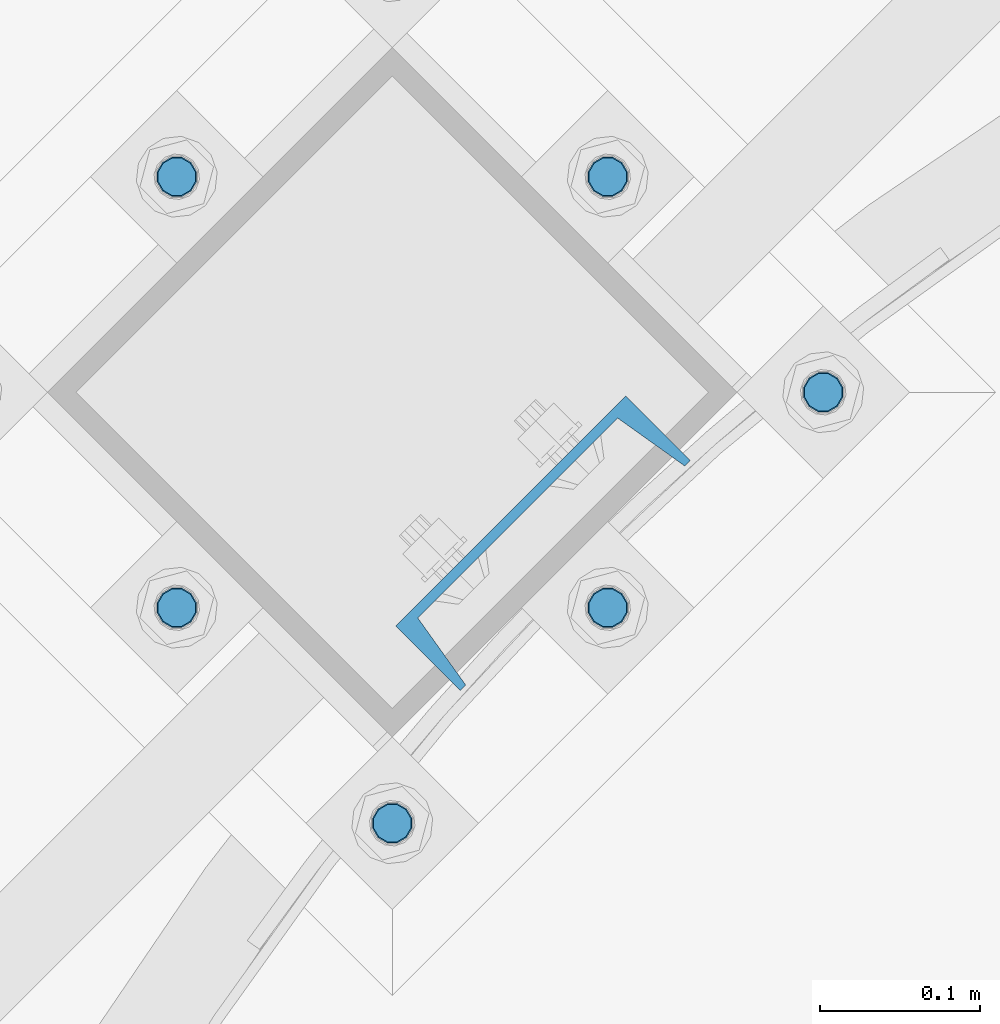
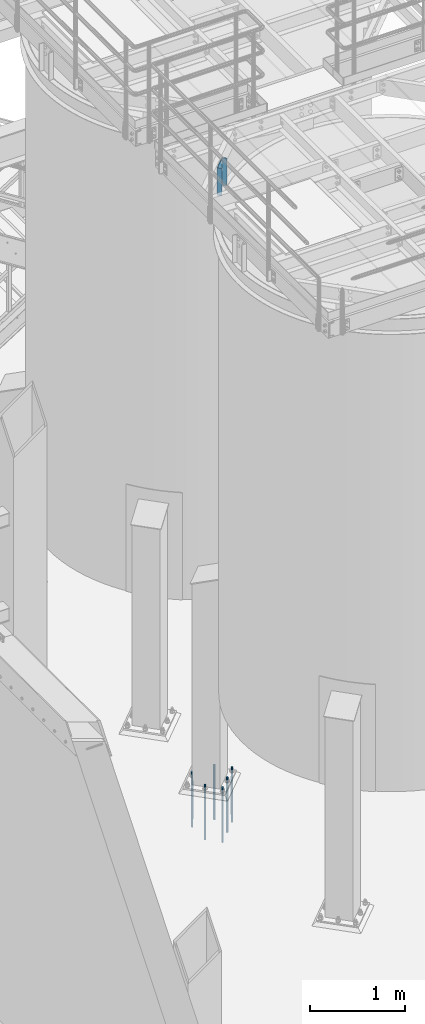
# One storey, part 787 of 1876: 7 columns, 2 elements without a shape of their own.
"""IFC2X3 building model written with IfcOpenShell, lengths in millimetres."""

from ifc_helpers import new_model, si_unit, frame, origin_with_axes, place, context, subcontext, project, spatial, faceted_brep, material, type_object, element, aggregate, save


model = new_model("IFC2X3")

# Units and contexts
model_context = context("Model", 3, precision=1e-05, world=origin_with_axes())
body_context = subcontext(model_context, "Body", "Model", "MODEL_VIEW")
ifc_project = project(units=[si_unit("LENGTHUNIT", "METRE", prefix="MILLI"), si_unit("AREAUNIT", "SQUARE_METRE"), si_unit("VOLUMEUNIT", "CUBIC_METRE"), si_unit("MASSUNIT", "GRAM", prefix="KILO"), si_unit("TIMEUNIT", "SECOND"), si_unit("PLANEANGLEUNIT", "RADIAN"), si_unit("SOLIDANGLEUNIT", "STERADIAN"), si_unit("THERMODYNAMICTEMPERATUREUNIT", "DEGREE_CELSIUS"), si_unit("LUMINOUSINTENSITYUNIT", "LUMEN")], contexts=[model_context])

# Site, building, storey
site_placement = place(None, origin_with_axes())
site = spatial("IfcSite", under=ifc_project, at=site_placement, CompositionType="ELEMENT")
building_placement = place(site_placement, origin_with_axes())
building = spatial("IfcBuilding", under=site, at=building_placement, Name="Undefined", CompositionType="ELEMENT")
storey_placement = place(building_placement, origin_with_axes())
storey = spatial("IfcBuildingStorey", under=building, at=storey_placement, Name="Undefined", CompositionType="ELEMENT", Elevation=0.0)

# Assembly, column
assembly_1_placement = place(storey_placement, origin_with_axes())
assembly_1 = element("IfcElementAssembly", 1, at=assembly_1_placement, inside=storey, Name="BEAM", AssemblyPlace="NOTDEFINED", PredefinedType="RIGID_FRAME")
ifc_material_1 = material(Name="STEEL/A36")
column_type_1 = type_object("IfcColumnType", Name="C8X11.5", PredefinedType="NOTDEFINED")
column_1_placement = place(assembly_1_placement, frame((3877.23669477331, -12284.6708589759, 7620.0), z_axis=(-0.707106781186547, -0.707106781186548, 0.0), x_axis=(0.0, 0.0, 1.0)))
column_1 = element("IfcColumn", 2, at=column_1_placement, type_object=column_type_1, material=ifc_material_1, Name="BEAM", ObjectType="C8X11.5", context=body_context, shape_type="Brep", body=[
    faceted_brep([(0.0, 28.5749999999998, -101.6), (0.0, 28.5749999999998, 101.6), (352.425, 28.5749999999998, 101.6), (352.425, 28.5749999999998, -101.6), (0.0, -28.5749999999998, 101.6), (352.425, -28.5749999999998, 101.6), (0.0, -28.5749999999998, 96.8355950000005), (352.425, -28.5749999999998, 96.8355950000005), (0.0, 22.2250000000004, 88.3723150000005), (352.425, 22.2250000000004, 88.3723150000005), (0.0, 22.2250000000004, -88.3723150000005), (352.425, 22.2250000000004, -88.3723150000005), (0.0, -28.5749999999998, -96.8355950000005), (352.425, -28.5749999999998, -96.8355950000005), (0.0, -28.5749999999998, -101.6), (352.425, -28.5749999999998, -101.6)], [[[0, 1, 2, 3]], [[1, 4, 5, 2]], [[4, 6, 7, 5]], [[6, 8, 9, 7]], [[8, 10, 11, 9]], [[10, 12, 13, 11]], [[12, 14, 15, 13]], [[14, 0, 3, 15]], [[5, 7, 9, 11, 13, 15, 3, 2]], [[14, 12, 10, 8, 6, 4, 1, 0]]]),
])
aggregate(assembly_1, [column_1])

# Assembly, columns
assembly_2_placement = place(storey_placement, origin_with_axes())
assembly_2 = element("IfcElementAssembly", 3, at=assembly_2_placement, inside=storey, Name="TEMPLATE", AssemblyPlace="NOTDEFINED", PredefinedType="RIGID_FRAME")
ifc_material_2 = material(Name="STEEL/F1554-GR.105")
column_type_2 = type_object("IfcColumnType", PredefinedType="NOTDEFINED")
column_2_placement = place(assembly_2_placement, frame((4052.42056299758, -12190.270378919, 7.105427357601e-15), z_axis=(0.707106781186548, 0.707106781186547, 0.0), x_axis=(0.0, 0.0, -1.0)))
column_2 = element("IfcColumn", 4, at=column_2_placement, type_object=column_type_2, material=ifc_material_2, Name="ANCHOR_BOLTS", context=body_context, shape_type="Brep", body=[
    faceted_brep([(-114.3, -10.3923048454853, 6.0000000001337), (-114.3, -6.00000000006912, 10.3923048455481), (-114.3, -6.54836185276508e-11, 12.0000000001355), (-114.3, 5.99999999993634, 10.3923048455481), (-114.3, 10.3923048453526, 6.00000000013279), (-114.3, 11.9999999999418, 1.29148247651756e-10), (-114.3, 10.3923048453507, -5.99999999987358), (-114.3, 5.99999999993815, -10.392304845288), (-114.3, -6.54836185276508e-11, -11.9999999998781), (-114.3, -6.00000000006912, -10.3923048452889), (-114.3, -10.3923048454853, -5.99999999987358), (-114.3, -12.0000000000728, 1.28238752949983e-10), (0.0, 11.9999999999418, 1.29148247651756e-10), (0.0, 10.3923048453507, -5.99999999987358), (0.0, 5.99999999993815, -10.392304845288), (0.0, -6.54836185276508e-11, -11.9999999998781), (0.0, -6.00000000006912, -10.3923048452889), (0.0, -10.3923048454853, -5.99999999987358), (0.0, -12.0000000000728, 1.28238752949983e-10), (0.0, -10.3923048454853, 6.0000000001337), (0.0, -6.00000000006912, 10.3923048455481), (0.0, -6.54836185276508e-11, 12.0000000001355), (0.0, 5.99999999993634, 10.3923048455481), (0.0, 10.3923048453526, 6.00000000013279), (0.0, -10.998522628066, 6.35000000000218), (0.0, -6.35000000000218, 10.9985226280642), (0.0, 0.0, 12.7000000000035), (0.0, 6.34999999999854, 10.9985226280651), (0.0, 10.9985226280623, 6.35000000000218), (0.0, 12.6999999999998, 0.0), (0.0, 10.9985226280623, -6.35000000000127), (0.0, 6.34999999999854, -10.9985226280633), (0.0, 0.0, -12.7000000000016), (0.0, -6.35000000000218, -10.9985226280642), (0.0, -10.998522628066, -6.35000000000127), (0.0, -12.6999999999998, 0.0), (488.95, -12.7000000000044, 9.09494701772928e-13), (488.95, -10.998522628066, 6.35000000000218), (488.95, -6.35000000000218, 10.9985226280642), (488.95, 0.0, 12.7000000000035), (488.95, 6.34999999999854, 10.9985226280651), (488.95, 10.9985226280623, 6.35000000000218), (488.95, 12.7000000000007, 9.09494701772928e-13), (488.95, 10.9985226280623, -6.35000000000127), (488.95, 6.34999999999854, -10.9985226280633), (488.95, 0.0, -12.7000000000016), (488.95, -6.35000000000218, -10.9985226280642), (488.95, -10.998522628066, -6.35000000000127), (488.95, -6.00000000006912, 10.3923048455481), (488.95, -6.54836185276508e-11, 12.0000000001355), (488.95, 5.99999999993634, 10.3923048455481), (488.95, 10.3923048453526, 6.00000000013279), (488.95, 11.9999999999418, 1.29148247651756e-10), (488.95, 10.3923048453507, -5.99999999987358), (488.95, 5.99999999993815, -10.392304845288), (488.95, -6.54836185276508e-11, -11.9999999998781), (488.95, -6.00000000006912, -10.3923048452889), (488.95, -10.3923048454853, -5.99999999987358), (488.95, -12.0000000000728, 1.28238752949983e-10), (488.95, -10.3923048454853, 6.0000000001337), (590.55, -6.00000000006912, -10.3923048452889), (590.55, -6.54836185276508e-11, -11.9999999998781), (590.55, 5.99999999993815, -10.392304845288), (590.55, 10.3923048453507, -5.99999999987358), (590.55, 11.9999999999418, 1.29148247651756e-10), (590.55, 10.3923048453526, 6.00000000013279), (590.55, 5.99999999993634, 10.3923048455481), (590.55, -6.54836185276508e-11, 12.0000000001355), (590.55, -6.00000000006912, 10.3923048455481), (590.55, -10.3923048454853, 6.0000000001337), (590.55, -12.0000000000728, 1.28238752949983e-10), (590.55, -10.3923048454853, -5.99999999987358)], [[[0, 1, 2, 3, 4, 5, 6, 7, 8, 9, 10, 11]], [[6, 5, 12, 13]], [[7, 6, 13, 14]], [[8, 7, 14, 15]], [[9, 8, 15, 16]], [[10, 9, 16, 17]], [[11, 10, 17, 18]], [[0, 11, 18, 19]], [[1, 0, 19, 20]], [[2, 1, 20, 21]], [[3, 2, 21, 22]], [[4, 3, 22, 23]], [[5, 4, 23, 12]], [[24, 25, 26, 27, 28, 29, 30, 31, 32, 33, 34, 35], [22, 21, 20, 19, 18, 17, 16, 15, 14, 13, 12, 23]], [[24, 35, 36, 37]], [[25, 24, 37, 38]], [[26, 25, 38, 39]], [[27, 26, 39, 40]], [[28, 27, 40, 41]], [[29, 28, 41, 42]], [[30, 29, 42, 43]], [[31, 30, 43, 44]], [[32, 31, 44, 45]], [[33, 32, 45, 46]], [[34, 33, 46, 47]], [[35, 34, 47, 36]], [[46, 45, 44, 43, 42, 41, 40, 39, 38, 37, 36, 47], [48, 49, 50, 51, 52, 53, 54, 55, 56, 57, 58, 59]], [[60, 61, 62, 63, 64, 65, 66, 67, 68, 69, 70, 71]], [[68, 67, 49, 48]], [[69, 68, 48, 59]], [[70, 69, 59, 58]], [[71, 70, 58, 57]], [[60, 71, 57, 56]], [[61, 60, 56, 55]], [[62, 61, 55, 54]], [[63, 62, 54, 53]], [[64, 63, 53, 52]], [[65, 64, 52, 51]], [[66, 65, 51, 50]], [[67, 66, 50, 49]]]),
])
column_3_placement = place(assembly_2_placement, frame((3917.71672118143, -12055.5665371028, 7.105427357601e-15), z_axis=(0.707106781186548, 0.707106781186547, 0.0), x_axis=(0.0, 0.0, -1.0)))
column_3 = element("IfcColumn", 5, at=column_3_placement, type_object=column_type_2, material=ifc_material_2, Name="ANCHOR_BOLTS", context=body_context, shape_type="Brep", body=[
    faceted_brep([(-114.3, -10.3923048454853, 6.0000000001337), (-114.3, -6.00000000006912, 10.3923048455481), (-114.3, -6.54836185276508e-11, 12.0000000001355), (-114.3, 5.99999999993634, 10.3923048455481), (-114.3, 10.3923048453526, 6.00000000013279), (-114.3, 11.9999999999418, 1.29148247651756e-10), (-114.3, 10.3923048453507, -5.99999999987358), (-114.3, 5.99999999993815, -10.392304845288), (-114.3, -6.54836185276508e-11, -11.9999999998781), (-114.3, -6.00000000006912, -10.3923048452889), (-114.3, -10.3923048454853, -5.99999999987358), (-114.3, -12.0000000000728, 1.28238752949983e-10), (0.0, 11.9999999999418, 1.29148247651756e-10), (0.0, 10.3923048453507, -5.99999999987358), (0.0, 5.99999999993815, -10.392304845288), (0.0, -6.54836185276508e-11, -11.9999999998781), (0.0, -6.00000000006912, -10.3923048452889), (0.0, -10.3923048454853, -5.99999999987358), (0.0, -12.0000000000728, 1.28238752949983e-10), (0.0, -10.3923048454853, 6.0000000001337), (0.0, -6.00000000006912, 10.3923048455481), (0.0, -6.54836185276508e-11, 12.0000000001355), (0.0, 5.99999999993634, 10.3923048455481), (0.0, 10.3923048453526, 6.00000000013279), (0.0, -10.998522628066, 6.35000000000218), (0.0, -6.35000000000218, 10.9985226280642), (0.0, 0.0, 12.7000000000035), (0.0, 6.34999999999854, 10.9985226280651), (0.0, 10.9985226280623, 6.35000000000218), (0.0, 12.6999999999998, 0.0), (0.0, 10.9985226280623, -6.35000000000127), (0.0, 6.34999999999854, -10.9985226280633), (0.0, 0.0, -12.7000000000016), (0.0, -6.35000000000218, -10.9985226280642), (0.0, -10.998522628066, -6.35000000000127), (0.0, -12.6999999999998, 0.0), (488.95, -12.7000000000044, 9.09494701772928e-13), (488.95, -10.998522628066, 6.35000000000218), (488.95, -6.35000000000218, 10.9985226280642), (488.95, 0.0, 12.7000000000035), (488.95, 6.34999999999854, 10.9985226280651), (488.95, 10.9985226280623, 6.35000000000218), (488.95, 12.7000000000007, 9.09494701772928e-13), (488.95, 10.9985226280623, -6.35000000000127), (488.95, 6.34999999999854, -10.9985226280633), (488.95, 0.0, -12.7000000000016), (488.95, -6.35000000000218, -10.9985226280642), (488.95, -10.998522628066, -6.35000000000127), (488.95, -6.00000000006912, 10.3923048455481), (488.95, -6.54836185276508e-11, 12.0000000001355), (488.95, 5.99999999993634, 10.3923048455481), (488.95, 10.3923048453526, 6.00000000013279), (488.95, 11.9999999999418, 1.29148247651756e-10), (488.95, 10.3923048453507, -5.99999999987358), (488.95, 5.99999999993815, -10.392304845288), (488.95, -6.54836185276508e-11, -11.9999999998781), (488.95, -6.00000000006912, -10.3923048452889), (488.95, -10.3923048454853, -5.99999999987358), (488.95, -12.0000000000728, 1.28238752949983e-10), (488.95, -10.3923048454853, 6.0000000001337), (590.55, -6.00000000006912, -10.3923048452889), (590.55, -6.54836185276508e-11, -11.9999999998781), (590.55, 5.99999999993815, -10.392304845288), (590.55, 10.3923048453507, -5.99999999987358), (590.55, 11.9999999999418, 1.29148247651756e-10), (590.55, 10.3923048453526, 6.00000000013279), (590.55, 5.99999999993634, 10.3923048455481), (590.55, -6.54836185276508e-11, 12.0000000001355), (590.55, -6.00000000006912, 10.3923048455481), (590.55, -10.3923048454853, 6.0000000001337), (590.55, -12.0000000000728, 1.28238752949983e-10), (590.55, -10.3923048454853, -5.99999999987358)], [[[0, 1, 2, 3, 4, 5, 6, 7, 8, 9, 10, 11]], [[6, 5, 12, 13]], [[7, 6, 13, 14]], [[8, 7, 14, 15]], [[9, 8, 15, 16]], [[10, 9, 16, 17]], [[11, 10, 17, 18]], [[0, 11, 18, 19]], [[1, 0, 19, 20]], [[2, 1, 20, 21]], [[3, 2, 21, 22]], [[4, 3, 22, 23]], [[5, 4, 23, 12]], [[24, 25, 26, 27, 28, 29, 30, 31, 32, 33, 34, 35], [22, 21, 20, 19, 18, 17, 16, 15, 14, 13, 12, 23]], [[24, 35, 36, 37]], [[25, 24, 37, 38]], [[26, 25, 38, 39]], [[27, 26, 39, 40]], [[28, 27, 40, 41]], [[29, 28, 41, 42]], [[30, 29, 42, 43]], [[31, 30, 43, 44]], [[32, 31, 44, 45]], [[33, 32, 45, 46]], [[34, 33, 46, 47]], [[35, 34, 47, 36]], [[46, 45, 44, 43, 42, 41, 40, 39, 38, 37, 36, 47], [48, 49, 50, 51, 52, 53, 54, 55, 56, 57, 58, 59]], [[60, 61, 62, 63, 64, 65, 66, 67, 68, 69, 70, 71]], [[68, 67, 49, 48]], [[69, 68, 48, 59]], [[70, 69, 59, 58]], [[71, 70, 58, 57]], [[60, 71, 57, 56]], [[61, 60, 56, 55]], [[62, 61, 55, 54]], [[63, 62, 54, 53]], [[64, 63, 53, 52]], [[65, 64, 52, 51]], [[66, 65, 51, 50]], [[67, 66, 50, 49]]]),
])
column_4_placement = place(assembly_2_placement, frame((3917.71672118143, -12324.9742207351, 7.105427357601e-15), z_axis=(0.707106781186548, 0.707106781186547, 0.0), x_axis=(0.0, 0.0, -1.0)))
column_4 = element("IfcColumn", 6, at=column_4_placement, type_object=column_type_2, material=ifc_material_2, Name="ANCHOR_BOLTS", context=body_context, shape_type="Brep", body=[
    faceted_brep([(-114.3, -10.3923048454853, 6.0000000001337), (-114.3, -6.00000000006912, 10.3923048455481), (-114.3, -6.54836185276508e-11, 12.0000000001355), (-114.3, 5.99999999993634, 10.3923048455481), (-114.3, 10.3923048453526, 6.00000000013279), (-114.3, 11.9999999999418, 1.29148247651756e-10), (-114.3, 10.3923048453507, -5.99999999987358), (-114.3, 5.99999999993815, -10.392304845288), (-114.3, -6.54836185276508e-11, -11.9999999998781), (-114.3, -6.00000000006912, -10.3923048452889), (-114.3, -10.3923048454853, -5.99999999987358), (-114.3, -12.0000000000728, 1.28238752949983e-10), (0.0, 11.9999999999418, 1.29148247651756e-10), (0.0, 10.3923048453507, -5.99999999987358), (0.0, 5.99999999993815, -10.392304845288), (0.0, -6.54836185276508e-11, -11.9999999998781), (0.0, -6.00000000006912, -10.3923048452889), (0.0, -10.3923048454853, -5.99999999987358), (0.0, -12.0000000000728, 1.28238752949983e-10), (0.0, -10.3923048454853, 6.0000000001337), (0.0, -6.00000000006912, 10.3923048455481), (0.0, -6.54836185276508e-11, 12.0000000001355), (0.0, 5.99999999993634, 10.3923048455481), (0.0, 10.3923048453526, 6.00000000013279), (0.0, -10.998522628066, 6.35000000000218), (0.0, -6.35000000000218, 10.9985226280642), (0.0, 0.0, 12.7000000000035), (0.0, 6.34999999999854, 10.9985226280651), (0.0, 10.9985226280623, 6.35000000000218), (0.0, 12.6999999999998, 0.0), (0.0, 10.9985226280623, -6.35000000000127), (0.0, 6.34999999999854, -10.9985226280633), (0.0, 0.0, -12.7000000000016), (0.0, -6.35000000000218, -10.9985226280642), (0.0, -10.998522628066, -6.35000000000127), (0.0, -12.6999999999998, 0.0), (488.95, -12.7000000000044, 9.09494701772928e-13), (488.95, -10.998522628066, 6.35000000000218), (488.95, -6.35000000000218, 10.9985226280642), (488.95, 0.0, 12.7000000000035), (488.95, 6.34999999999854, 10.9985226280651), (488.95, 10.9985226280623, 6.35000000000218), (488.95, 12.7000000000007, 9.09494701772928e-13), (488.95, 10.9985226280623, -6.35000000000127), (488.95, 6.34999999999854, -10.9985226280633), (488.95, 0.0, -12.7000000000016), (488.95, -6.35000000000218, -10.9985226280642), (488.95, -10.998522628066, -6.35000000000127), (488.95, -6.00000000006912, 10.3923048455481), (488.95, -6.54836185276508e-11, 12.0000000001355), (488.95, 5.99999999993634, 10.3923048455481), (488.95, 10.3923048453526, 6.00000000013279), (488.95, 11.9999999999418, 1.29148247651756e-10), (488.95, 10.3923048453507, -5.99999999987358), (488.95, 5.99999999993815, -10.392304845288), (488.95, -6.54836185276508e-11, -11.9999999998781), (488.95, -6.00000000006912, -10.3923048452889), (488.95, -10.3923048454853, -5.99999999987358), (488.95, -12.0000000000728, 1.28238752949983e-10), (488.95, -10.3923048454853, 6.0000000001337), (590.55, -6.00000000006912, -10.3923048452889), (590.55, -6.54836185276508e-11, -11.9999999998781), (590.55, 5.99999999993815, -10.392304845288), (590.55, 10.3923048453507, -5.99999999987358), (590.55, 11.9999999999418, 1.29148247651756e-10), (590.55, 10.3923048453526, 6.00000000013279), (590.55, 5.99999999993634, 10.3923048455481), (590.55, -6.54836185276508e-11, 12.0000000001355), (590.55, -6.00000000006912, 10.3923048455481), (590.55, -10.3923048454853, 6.0000000001337), (590.55, -12.0000000000728, 1.28238752949983e-10), (590.55, -10.3923048454853, -5.99999999987358)], [[[0, 1, 2, 3, 4, 5, 6, 7, 8, 9, 10, 11]], [[6, 5, 12, 13]], [[7, 6, 13, 14]], [[8, 7, 14, 15]], [[9, 8, 15, 16]], [[10, 9, 16, 17]], [[11, 10, 17, 18]], [[0, 11, 18, 19]], [[1, 0, 19, 20]], [[2, 1, 20, 21]], [[3, 2, 21, 22]], [[4, 3, 22, 23]], [[5, 4, 23, 12]], [[24, 25, 26, 27, 28, 29, 30, 31, 32, 33, 34, 35], [22, 21, 20, 19, 18, 17, 16, 15, 14, 13, 12, 23]], [[24, 35, 36, 37]], [[25, 24, 37, 38]], [[26, 25, 38, 39]], [[27, 26, 39, 40]], [[28, 27, 40, 41]], [[29, 28, 41, 42]], [[30, 29, 42, 43]], [[31, 30, 43, 44]], [[32, 31, 44, 45]], [[33, 32, 45, 46]], [[34, 33, 46, 47]], [[35, 34, 47, 36]], [[46, 45, 44, 43, 42, 41, 40, 39, 38, 37, 36, 47], [48, 49, 50, 51, 52, 53, 54, 55, 56, 57, 58, 59]], [[60, 61, 62, 63, 64, 65, 66, 67, 68, 69, 70, 71]], [[68, 67, 49, 48]], [[69, 68, 48, 59]], [[70, 69, 59, 58]], [[71, 70, 58, 57]], [[60, 71, 57, 56]], [[61, 60, 56, 55]], [[62, 61, 55, 54]], [[63, 62, 54, 53]], [[64, 63, 53, 52]], [[65, 64, 52, 51]], [[66, 65, 51, 50]], [[67, 66, 50, 49]]]),
])
column_5_placement = place(assembly_2_placement, frame((3648.30903754913, -12055.5665371028, 7.105427357601e-15), z_axis=(-0.707106781186547, -0.707106781186548, 0.0), x_axis=(0.0, 0.0, -1.0)))
column_5 = element("IfcColumn", 7, at=column_5_placement, type_object=column_type_2, material=ifc_material_2, Name="ANCHOR_BOLTS", context=body_context, shape_type="Brep", body=[
    faceted_brep([(-114.3, -10.3923048454853, 6.0000000001337), (-114.3, -6.00000000006912, 10.3923048455481), (-114.3, -6.54836185276508e-11, 12.0000000001355), (-114.3, 5.99999999993634, 10.3923048455481), (-114.3, 10.3923048453526, 6.00000000013279), (-114.3, 11.9999999999418, 1.29148247651756e-10), (-114.3, 10.3923048453507, -5.99999999987358), (-114.3, 5.99999999993815, -10.392304845288), (-114.3, -6.54836185276508e-11, -11.9999999998781), (-114.3, -6.00000000006912, -10.3923048452889), (-114.3, -10.3923048454853, -5.99999999987358), (-114.3, -12.0000000000728, 1.28238752949983e-10), (0.0, 11.9999999999418, 1.29148247651756e-10), (0.0, 10.3923048453507, -5.99999999987358), (0.0, 5.99999999993815, -10.392304845288), (0.0, -6.54836185276508e-11, -11.9999999998781), (0.0, -6.00000000006912, -10.3923048452889), (0.0, -10.3923048454853, -5.99999999987358), (0.0, -12.0000000000728, 1.28238752949983e-10), (0.0, -10.3923048454853, 6.0000000001337), (0.0, -6.00000000006912, 10.3923048455481), (0.0, -6.54836185276508e-11, 12.0000000001355), (0.0, 5.99999999993634, 10.3923048455481), (0.0, 10.3923048453526, 6.00000000013279), (0.0, -10.998522628066, 6.35000000000218), (0.0, -6.35000000000218, 10.9985226280642), (0.0, 0.0, 12.7000000000035), (0.0, 6.34999999999854, 10.9985226280651), (0.0, 10.9985226280623, 6.35000000000218), (0.0, 12.6999999999998, 0.0), (0.0, 10.9985226280623, -6.35000000000127), (0.0, 6.34999999999854, -10.9985226280633), (0.0, 0.0, -12.7000000000016), (0.0, -6.35000000000218, -10.9985226280642), (0.0, -10.998522628066, -6.35000000000127), (0.0, -12.6999999999998, 0.0), (488.95, -12.7000000000044, 9.09494701772928e-13), (488.95, -10.998522628066, 6.35000000000218), (488.95, -6.35000000000218, 10.9985226280642), (488.95, 0.0, 12.7000000000035), (488.95, 6.34999999999854, 10.9985226280651), (488.95, 10.9985226280623, 6.35000000000218), (488.95, 12.7000000000007, 9.09494701772928e-13), (488.95, 10.9985226280623, -6.35000000000127), (488.95, 6.34999999999854, -10.9985226280633), (488.95, 0.0, -12.7000000000016), (488.95, -6.35000000000218, -10.9985226280642), (488.95, -10.998522628066, -6.35000000000127), (488.95, -6.00000000006912, 10.3923048455481), (488.95, -6.54836185276508e-11, 12.0000000001355), (488.95, 5.99999999993634, 10.3923048455481), (488.95, 10.3923048453526, 6.00000000013279), (488.95, 11.9999999999418, 1.29148247651756e-10), (488.95, 10.3923048453507, -5.99999999987358), (488.95, 5.99999999993815, -10.392304845288), (488.95, -6.54836185276508e-11, -11.9999999998781), (488.95, -6.00000000006912, -10.3923048452889), (488.95, -10.3923048454853, -5.99999999987358), (488.95, -12.0000000000728, 1.28238752949983e-10), (488.95, -10.3923048454853, 6.0000000001337), (590.55, -6.00000000006912, -10.3923048452889), (590.55, -6.54836185276508e-11, -11.9999999998781), (590.55, 5.99999999993815, -10.392304845288), (590.55, 10.3923048453507, -5.99999999987358), (590.55, 11.9999999999418, 1.29148247651756e-10), (590.55, 10.3923048453526, 6.00000000013279), (590.55, 5.99999999993634, 10.3923048455481), (590.55, -6.54836185276508e-11, 12.0000000001355), (590.55, -6.00000000006912, 10.3923048455481), (590.55, -10.3923048454853, 6.0000000001337), (590.55, -12.0000000000728, 1.28238752949983e-10), (590.55, -10.3923048454853, -5.99999999987358)], [[[0, 1, 2, 3, 4, 5, 6, 7, 8, 9, 10, 11]], [[6, 5, 12, 13]], [[7, 6, 13, 14]], [[8, 7, 14, 15]], [[9, 8, 15, 16]], [[10, 9, 16, 17]], [[11, 10, 17, 18]], [[0, 11, 18, 19]], [[1, 0, 19, 20]], [[2, 1, 20, 21]], [[3, 2, 21, 22]], [[4, 3, 22, 23]], [[5, 4, 23, 12]], [[24, 25, 26, 27, 28, 29, 30, 31, 32, 33, 34, 35], [22, 21, 20, 19, 18, 17, 16, 15, 14, 13, 12, 23]], [[24, 35, 36, 37]], [[25, 24, 37, 38]], [[26, 25, 38, 39]], [[27, 26, 39, 40]], [[28, 27, 40, 41]], [[29, 28, 41, 42]], [[30, 29, 42, 43]], [[31, 30, 43, 44]], [[32, 31, 44, 45]], [[33, 32, 45, 46]], [[34, 33, 46, 47]], [[35, 34, 47, 36]], [[46, 45, 44, 43, 42, 41, 40, 39, 38, 37, 36, 47], [48, 49, 50, 51, 52, 53, 54, 55, 56, 57, 58, 59]], [[60, 61, 62, 63, 64, 65, 66, 67, 68, 69, 70, 71]], [[68, 67, 49, 48]], [[69, 68, 48, 59]], [[70, 69, 59, 58]], [[71, 70, 58, 57]], [[60, 71, 57, 56]], [[61, 60, 56, 55]], [[62, 61, 55, 54]], [[63, 62, 54, 53]], [[64, 63, 53, 52]], [[65, 64, 52, 51]], [[66, 65, 51, 50]], [[67, 66, 50, 49]]]),
])
column_6_placement = place(assembly_2_placement, frame((3783.01287936528, -12459.6780625513, 7.105427357601e-15), z_axis=(0.707106781186548, 0.707106781186547, 0.0), x_axis=(0.0, 0.0, -1.0)))
column_6 = element("IfcColumn", 8, at=column_6_placement, type_object=column_type_2, material=ifc_material_2, Name="ANCHOR_BOLTS", context=body_context, shape_type="Brep", body=[
    faceted_brep([(-114.3, -10.3923048454853, 6.0000000001337), (-114.3, -6.00000000006912, 10.3923048455481), (-114.3, -6.54836185276508e-11, 12.0000000001355), (-114.3, 5.99999999993634, 10.3923048455481), (-114.3, 10.3923048453526, 6.00000000013279), (-114.3, 11.9999999999418, 1.29148247651756e-10), (-114.3, 10.3923048453507, -5.99999999987358), (-114.3, 5.99999999993815, -10.392304845288), (-114.3, -6.54836185276508e-11, -11.9999999998781), (-114.3, -6.00000000006912, -10.3923048452889), (-114.3, -10.3923048454853, -5.99999999987358), (-114.3, -12.0000000000728, 1.28238752949983e-10), (0.0, 11.9999999999418, 1.29148247651756e-10), (0.0, 10.3923048453507, -5.99999999987358), (0.0, 5.99999999993815, -10.392304845288), (0.0, -6.54836185276508e-11, -11.9999999998781), (0.0, -6.00000000006912, -10.3923048452889), (0.0, -10.3923048454853, -5.99999999987358), (0.0, -12.0000000000728, 1.28238752949983e-10), (0.0, -10.3923048454853, 6.0000000001337), (0.0, -6.00000000006912, 10.3923048455481), (0.0, -6.54836185276508e-11, 12.0000000001355), (0.0, 5.99999999993634, 10.3923048455481), (0.0, 10.3923048453526, 6.00000000013279), (0.0, -10.998522628066, 6.35000000000218), (0.0, -6.35000000000218, 10.9985226280642), (0.0, 0.0, 12.7000000000035), (0.0, 6.34999999999854, 10.9985226280651), (0.0, 10.9985226280623, 6.35000000000218), (0.0, 12.6999999999998, 0.0), (0.0, 10.9985226280623, -6.35000000000127), (0.0, 6.34999999999854, -10.9985226280633), (0.0, 0.0, -12.7000000000016), (0.0, -6.35000000000218, -10.9985226280642), (0.0, -10.998522628066, -6.35000000000127), (0.0, -12.6999999999998, 0.0), (488.95, -12.7000000000044, 9.09494701772928e-13), (488.95, -10.998522628066, 6.35000000000218), (488.95, -6.35000000000218, 10.9985226280642), (488.95, 0.0, 12.7000000000035), (488.95, 6.34999999999854, 10.9985226280651), (488.95, 10.9985226280623, 6.35000000000218), (488.95, 12.7000000000007, 9.09494701772928e-13), (488.95, 10.9985226280623, -6.35000000000127), (488.95, 6.34999999999854, -10.9985226280633), (488.95, 0.0, -12.7000000000016), (488.95, -6.35000000000218, -10.9985226280642), (488.95, -10.998522628066, -6.35000000000127), (488.95, -6.00000000006912, 10.3923048455481), (488.95, -6.54836185276508e-11, 12.0000000001355), (488.95, 5.99999999993634, 10.3923048455481), (488.95, 10.3923048453526, 6.00000000013279), (488.95, 11.9999999999418, 1.29148247651756e-10), (488.95, 10.3923048453507, -5.99999999987358), (488.95, 5.99999999993815, -10.392304845288), (488.95, -6.54836185276508e-11, -11.9999999998781), (488.95, -6.00000000006912, -10.3923048452889), (488.95, -10.3923048454853, -5.99999999987358), (488.95, -12.0000000000728, 1.28238752949983e-10), (488.95, -10.3923048454853, 6.0000000001337), (590.55, -6.00000000006912, -10.3923048452889), (590.55, -6.54836185276508e-11, -11.9999999998781), (590.55, 5.99999999993815, -10.392304845288), (590.55, 10.3923048453507, -5.99999999987358), (590.55, 11.9999999999418, 1.29148247651756e-10), (590.55, 10.3923048453526, 6.00000000013279), (590.55, 5.99999999993634, 10.3923048455481), (590.55, -6.54836185276508e-11, 12.0000000001355), (590.55, -6.00000000006912, 10.3923048455481), (590.55, -10.3923048454853, 6.0000000001337), (590.55, -12.0000000000728, 1.28238752949983e-10), (590.55, -10.3923048454853, -5.99999999987358)], [[[0, 1, 2, 3, 4, 5, 6, 7, 8, 9, 10, 11]], [[6, 5, 12, 13]], [[7, 6, 13, 14]], [[8, 7, 14, 15]], [[9, 8, 15, 16]], [[10, 9, 16, 17]], [[11, 10, 17, 18]], [[0, 11, 18, 19]], [[1, 0, 19, 20]], [[2, 1, 20, 21]], [[3, 2, 21, 22]], [[4, 3, 22, 23]], [[5, 4, 23, 12]], [[24, 25, 26, 27, 28, 29, 30, 31, 32, 33, 34, 35], [22, 21, 20, 19, 18, 17, 16, 15, 14, 13, 12, 23]], [[24, 35, 36, 37]], [[25, 24, 37, 38]], [[26, 25, 38, 39]], [[27, 26, 39, 40]], [[28, 27, 40, 41]], [[29, 28, 41, 42]], [[30, 29, 42, 43]], [[31, 30, 43, 44]], [[32, 31, 44, 45]], [[33, 32, 45, 46]], [[34, 33, 46, 47]], [[35, 34, 47, 36]], [[46, 45, 44, 43, 42, 41, 40, 39, 38, 37, 36, 47], [48, 49, 50, 51, 52, 53, 54, 55, 56, 57, 58, 59]], [[60, 61, 62, 63, 64, 65, 66, 67, 68, 69, 70, 71]], [[68, 67, 49, 48]], [[69, 68, 48, 59]], [[70, 69, 59, 58]], [[71, 70, 58, 57]], [[60, 71, 57, 56]], [[61, 60, 56, 55]], [[62, 61, 55, 54]], [[63, 62, 54, 53]], [[64, 63, 53, 52]], [[65, 64, 52, 51]], [[66, 65, 51, 50]], [[67, 66, 50, 49]]]),
])
column_7_placement = place(assembly_2_placement, frame((3648.30903754913, -12324.9742207351, 7.105427357601e-15), z_axis=(0.707106781186548, 0.707106781186547, 0.0), x_axis=(0.0, 0.0, -1.0)))
column_7 = element("IfcColumn", 9, at=column_7_placement, type_object=column_type_2, material=ifc_material_2, Name="ANCHOR_BOLTS", context=body_context, shape_type="Brep", body=[
    faceted_brep([(-114.3, -10.3923048454853, 6.0000000001337), (-114.3, -6.00000000006912, 10.3923048455481), (-114.3, -6.54836185276508e-11, 12.0000000001355), (-114.3, 5.99999999993634, 10.3923048455481), (-114.3, 10.3923048453526, 6.00000000013279), (-114.3, 11.9999999999418, 1.29148247651756e-10), (-114.3, 10.3923048453507, -5.99999999987358), (-114.3, 5.99999999993815, -10.392304845288), (-114.3, -6.54836185276508e-11, -11.9999999998781), (-114.3, -6.00000000006912, -10.3923048452889), (-114.3, -10.3923048454853, -5.99999999987358), (-114.3, -12.0000000000728, 1.28238752949983e-10), (0.0, 11.9999999999418, 1.29148247651756e-10), (0.0, 10.3923048453507, -5.99999999987358), (0.0, 5.99999999993815, -10.392304845288), (0.0, -6.54836185276508e-11, -11.9999999998781), (0.0, -6.00000000006912, -10.3923048452889), (0.0, -10.3923048454853, -5.99999999987358), (0.0, -12.0000000000728, 1.28238752949983e-10), (0.0, -10.3923048454853, 6.0000000001337), (0.0, -6.00000000006912, 10.3923048455481), (0.0, -6.54836185276508e-11, 12.0000000001355), (0.0, 5.99999999993634, 10.3923048455481), (0.0, 10.3923048453526, 6.00000000013279), (0.0, -10.998522628066, 6.35000000000218), (0.0, -6.35000000000218, 10.9985226280642), (0.0, 0.0, 12.7000000000035), (0.0, 6.34999999999854, 10.9985226280651), (0.0, 10.9985226280623, 6.35000000000218), (0.0, 12.6999999999998, 0.0), (0.0, 10.9985226280623, -6.35000000000127), (0.0, 6.34999999999854, -10.9985226280633), (0.0, 0.0, -12.7000000000016), (0.0, -6.35000000000218, -10.9985226280642), (0.0, -10.998522628066, -6.35000000000127), (0.0, -12.6999999999998, 0.0), (488.95, -12.7000000000044, 9.09494701772928e-13), (488.95, -10.998522628066, 6.35000000000218), (488.95, -6.35000000000218, 10.9985226280642), (488.95, 0.0, 12.7000000000035), (488.95, 6.34999999999854, 10.9985226280651), (488.95, 10.9985226280623, 6.35000000000218), (488.95, 12.7000000000007, 9.09494701772928e-13), (488.95, 10.9985226280623, -6.35000000000127), (488.95, 6.34999999999854, -10.9985226280633), (488.95, 0.0, -12.7000000000016), (488.95, -6.35000000000218, -10.9985226280642), (488.95, -10.998522628066, -6.35000000000127), (488.95, -6.00000000006912, 10.3923048455481), (488.95, -6.54836185276508e-11, 12.0000000001355), (488.95, 5.99999999993634, 10.3923048455481), (488.95, 10.3923048453526, 6.00000000013279), (488.95, 11.9999999999418, 1.29148247651756e-10), (488.95, 10.3923048453507, -5.99999999987358), (488.95, 5.99999999993815, -10.392304845288), (488.95, -6.54836185276508e-11, -11.9999999998781), (488.95, -6.00000000006912, -10.3923048452889), (488.95, -10.3923048454853, -5.99999999987358), (488.95, -12.0000000000728, 1.28238752949983e-10), (488.95, -10.3923048454853, 6.0000000001337), (590.55, -6.00000000006912, -10.3923048452889), (590.55, -6.54836185276508e-11, -11.9999999998781), (590.55, 5.99999999993815, -10.392304845288), (590.55, 10.3923048453507, -5.99999999987358), (590.55, 11.9999999999418, 1.29148247651756e-10), (590.55, 10.3923048453526, 6.00000000013279), (590.55, 5.99999999993634, 10.3923048455481), (590.55, -6.54836185276508e-11, 12.0000000001355), (590.55, -6.00000000006912, 10.3923048455481), (590.55, -10.3923048454853, 6.0000000001337), (590.55, -12.0000000000728, 1.28238752949983e-10), (590.55, -10.3923048454853, -5.99999999987358)], [[[0, 1, 2, 3, 4, 5, 6, 7, 8, 9, 10, 11]], [[6, 5, 12, 13]], [[7, 6, 13, 14]], [[8, 7, 14, 15]], [[9, 8, 15, 16]], [[10, 9, 16, 17]], [[11, 10, 17, 18]], [[0, 11, 18, 19]], [[1, 0, 19, 20]], [[2, 1, 20, 21]], [[3, 2, 21, 22]], [[4, 3, 22, 23]], [[5, 4, 23, 12]], [[24, 25, 26, 27, 28, 29, 30, 31, 32, 33, 34, 35], [22, 21, 20, 19, 18, 17, 16, 15, 14, 13, 12, 23]], [[24, 35, 36, 37]], [[25, 24, 37, 38]], [[26, 25, 38, 39]], [[27, 26, 39, 40]], [[28, 27, 40, 41]], [[29, 28, 41, 42]], [[30, 29, 42, 43]], [[31, 30, 43, 44]], [[32, 31, 44, 45]], [[33, 32, 45, 46]], [[34, 33, 46, 47]], [[35, 34, 47, 36]], [[46, 45, 44, 43, 42, 41, 40, 39, 38, 37, 36, 47], [48, 49, 50, 51, 52, 53, 54, 55, 56, 57, 58, 59]], [[60, 61, 62, 63, 64, 65, 66, 67, 68, 69, 70, 71]], [[68, 67, 49, 48]], [[69, 68, 48, 59]], [[70, 69, 59, 58]], [[71, 70, 58, 57]], [[60, 71, 57, 56]], [[61, 60, 56, 55]], [[62, 61, 55, 54]], [[63, 62, 54, 53]], [[64, 63, 53, 52]], [[65, 64, 52, 51]], [[66, 65, 51, 50]], [[67, 66, 50, 49]]]),
])
aggregate(assembly_2, [column_2, column_3, column_4, column_5, column_6, column_7])

save(model, "model.ifc")
